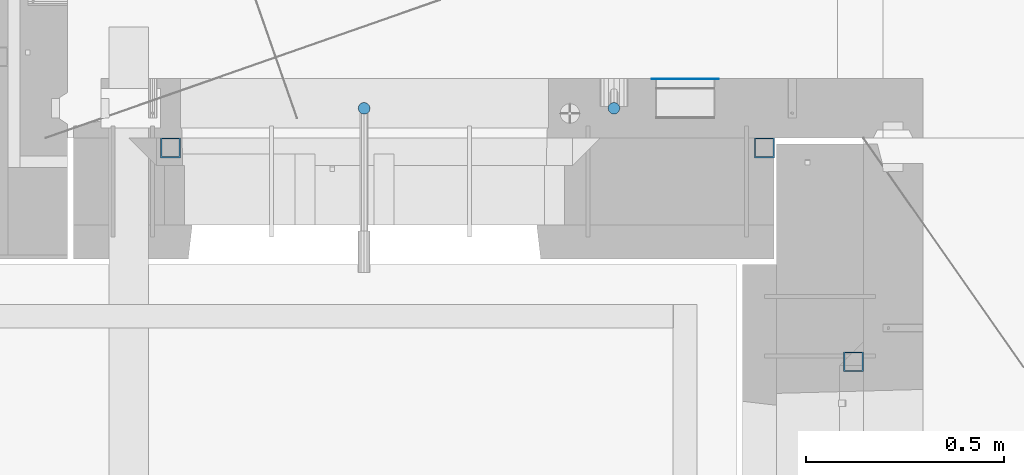
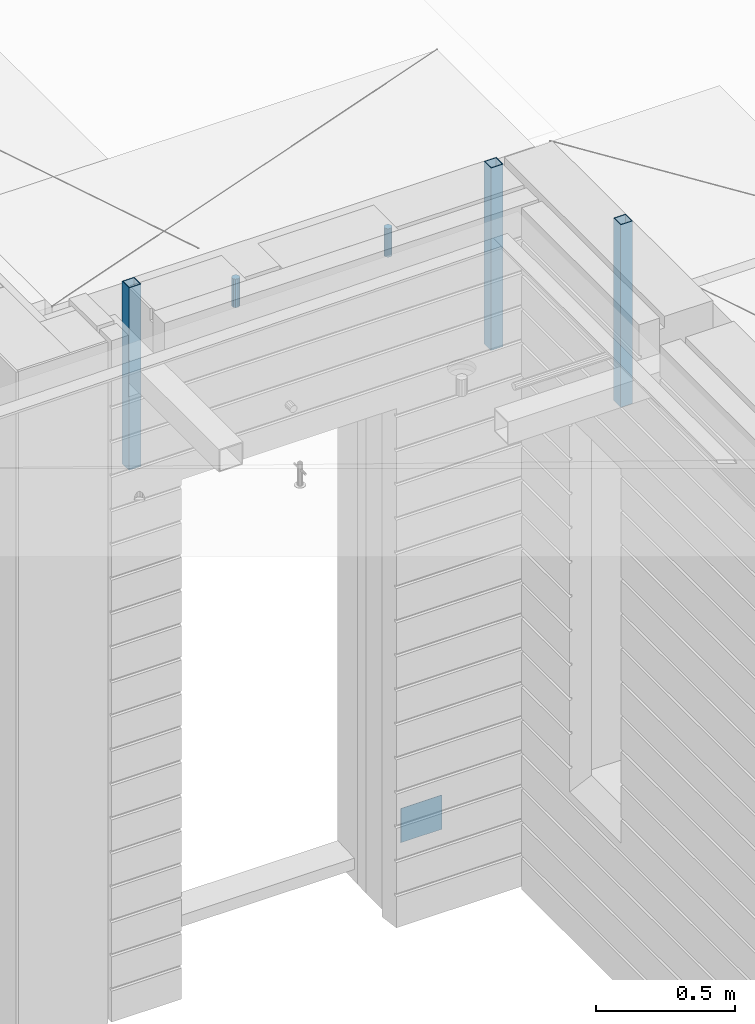
# One storey, part 12 of 349: 6 columns, 6 elements without a shape of their own.
"""IFC2X3 building model written with IfcOpenShell, lengths in millimetres."""

from ifc_helpers import new_model, si_unit, frame, origin_with_axes, place, context, subcontext, project, spatial, faceted_brep, material, type_object, element, aggregate, save


model = new_model("IFC2X3")

# Units and contexts
model_context = context("Model", 3, precision=1e-05, world=origin_with_axes())
body_context = subcontext(model_context, "Body", "Model", "MODEL_VIEW")
ifc_project = project(units=[si_unit("LENGTHUNIT", "METRE", prefix="MILLI"), si_unit("AREAUNIT", "SQUARE_METRE"), si_unit("VOLUMEUNIT", "CUBIC_METRE"), si_unit("MASSUNIT", "GRAM", prefix="KILO"), si_unit("TIMEUNIT", "SECOND"), si_unit("PLANEANGLEUNIT", "RADIAN"), si_unit("SOLIDANGLEUNIT", "STERADIAN"), si_unit("THERMODYNAMICTEMPERATUREUNIT", "DEGREE_CELSIUS"), si_unit("LUMINOUSINTENSITYUNIT", "LUMEN")], contexts=[model_context])

# Site, building, storey
site_placement = place(None, origin_with_axes())
site = spatial("IfcSite", under=ifc_project, at=site_placement, CompositionType="ELEMENT")
building_placement = place(site_placement, origin_with_axes())
building = spatial("IfcBuilding", under=site, at=building_placement, CompositionType="ELEMENT")
storey_placement = place(building_placement, origin_with_axes())
storey = spatial("IfcBuildingStorey", under=building, at=storey_placement, Name="4", CompositionType="ELEMENT", Elevation=0.0)

# Assemblies, columns
assembly_1_placement = place(storey_placement, origin_with_axes())
assembly_1 = element("IfcElementAssembly", 1, at=assembly_1_placement, inside=storey, AssemblyPlace="NOTDEFINED", PredefinedType="REINFORCEMENT_UNIT")
ifc_material_1 = material()
column_type_1 = type_object("IfcColumnType", Name="D30", PredefinedType="NOTDEFINED")
column_1_placement = place(assembly_1_placement, frame((9379.99827996565, 11025.0, 93407.5), z_axis=(0.0, -1.0, 0.0), x_axis=(0.0, 0.0, 1.0)))
column_1 = element("IfcColumn", 2, at=column_1_placement, type_object=column_type_1, material=ifc_material_1, ObjectType="D30", context=body_context, shape_type="Brep", body=[
    faceted_brep([(0.0, -15.0, 0.0), (0.0, -12.9903810567666, -7.5), (125.0, -12.9903810567666, -7.5), (125.0, -15.0, 0.0), (0.0, -7.5, -12.9903810567666), (125.0, -7.5, -12.9903810567666), (0.0, 0.0, -15.0), (125.0, 0.0, -15.0), (0.0, 7.5, -12.9903810567666), (125.0, 7.5, -12.9903810567666), (0.0, 12.9903810567666, -7.5), (125.0, 12.9903810567666, -7.5), (0.0, 15.0, 0.0), (125.0, 15.0, 0.0), (0.0, 12.9903810567666, 7.5), (125.0, 12.9903810567666, 7.5), (0.0, 7.5, 12.9903810567666), (125.0, 7.5, 12.9903810567666), (0.0, 0.0, 15.0), (125.0, 0.0, 15.0), (0.0, -7.5, 12.9903810567666), (125.0, -7.5, 12.9903810567666), (0.0, -12.9903810567666, 7.5), (125.0, -12.9903810567666, 7.5)], [[[0, 1, 2, 3]], [[1, 4, 5, 2]], [[4, 6, 7, 5]], [[6, 8, 9, 7]], [[8, 10, 11, 9]], [[10, 12, 13, 11]], [[12, 14, 15, 13]], [[14, 16, 17, 15]], [[16, 18, 19, 17]], [[18, 20, 21, 19]], [[20, 22, 23, 21]], [[22, 0, 3, 23]], [[5, 7, 9, 11, 13, 15, 17, 19, 21, 23, 3, 2]], [[22, 20, 18, 16, 14, 12, 10, 8, 6, 4, 1, 0]]]),
])
column_2_placement = place(assembly_1_placement, frame((8748.99633326467, 11025.0000000071, 93407.5), z_axis=(0.0, 1.0, 0.0), x_axis=(0.0, 0.0, 1.0)))
column_2 = element("IfcColumn", 3, at=column_2_placement, type_object=column_type_1, material=ifc_material_1, ObjectType="D30", context=body_context, shape_type="Brep", body=[
    faceted_brep([(0.0, -15.0, 0.0), (0.0, -12.9903810567666, -7.5), (125.0, -12.9903810567666, -7.5), (125.0, -15.0, 0.0), (0.0, -7.5, -12.9903810567666), (125.0, -7.5, -12.9903810567666), (0.0, 0.0, -15.0), (125.0, 0.0, -15.0), (0.0, 7.5, -12.9903810567666), (125.0, 7.5, -12.9903810567666), (0.0, 12.9903810567666, -7.5), (125.0, 12.9903810567666, -7.5), (0.0, 15.0, 0.0), (125.0, 15.0, 0.0), (0.0, 12.9903810567666, 7.5), (125.0, 12.9903810567666, 7.5), (0.0, 7.5, 12.9903810567666), (125.0, 7.5, 12.9903810567666), (0.0, 0.0, 15.0), (125.0, 0.0, 15.0), (0.0, -7.5, 12.9903810567666), (125.0, -7.5, 12.9903810567666), (0.0, -12.9903810567666, 7.5), (125.0, -12.9903810567666, 7.5)], [[[0, 1, 2, 3]], [[1, 4, 5, 2]], [[4, 6, 7, 5]], [[6, 8, 9, 7]], [[8, 10, 11, 9]], [[10, 12, 13, 11]], [[12, 14, 15, 13]], [[14, 16, 17, 15]], [[16, 18, 19, 17]], [[18, 20, 21, 19]], [[20, 22, 23, 21]], [[22, 0, 3, 23]], [[5, 7, 9, 11, 13, 15, 17, 19, 21, 23, 3, 2]], [[22, 20, 18, 16, 14, 12, 10, 8, 6, 4, 1, 0]]]),
])
assembly_2_placement = place(assembly_1_placement, origin_with_axes())
assembly_2 = element("IfcElementAssembly", 4, at=assembly_2_placement, Name="Steel Assembly", AssemblyPlace="NOTDEFINED", PredefinedType="NOTDEFINED")
ifc_material_2 = material(Name="Undefined")
column_type_2 = type_object("IfcColumnType", PredefinedType="NOTDEFINED")
column_3_placement = place(assembly_2_placement, frame((9560.0000000031, 11098.9999999984, 90754.9999999985), z_axis=(0.0, 1.0, 0.0), x_axis=(0.0, 0.0, 1.0)))
column_3 = element("IfcColumn", 5, at=column_3_placement, type_object=column_type_2, material=ifc_material_2, Name="SPK2", context=body_context, shape_type="Brep", body=[
    faceted_brep([(0.0, 85.0, -1.0), (0.0, 85.0, 1.0), (150.0, 85.0, 1.0), (150.0, 85.0, -1.0), (0.0, -85.0, 1.0), (150.0, -85.0, 1.0), (0.0, -85.0, -1.0), (150.0, -85.0, -1.0)], [[[0, 1, 2, 3]], [[1, 4, 5, 2]], [[4, 6, 7, 5]], [[6, 0, 3, 7]], [[5, 7, 3, 2]], [[6, 4, 1, 0]]]),
])
aggregate(assembly_2, [column_3])
assembly_3_placement = place(assembly_1_placement, origin_with_axes())
assembly_3 = element("IfcElementAssembly", 6, at=assembly_3_placement, Name="Steel Assembly", AssemblyPlace="NOTDEFINED", PredefinedType="RIGID_FRAME")
ifc_material_3 = material(Name="STEEL/S355J2")
column_type_3 = type_object("IfcColumnType", Name="50X50X3", PredefinedType="NOTDEFINED")
column_4_placement = place(assembly_3_placement, frame((8260.0, 10925.0, 92940.0), z_axis=(1.0, 0.0, 0.0), x_axis=(0.0, 0.0, 1.0)))
column_4 = element("IfcColumn", 7, at=column_4_placement, type_object=column_type_3, material=ifc_material_3, ObjectType="50X50X3", context=body_context, shape_type="Brep", body=[
    faceted_brep([(0.0, 22.0, -22.0), (0.0, -22.0, -22.0), (800.0, -22.0, -22.0), (800.0, 22.0, -22.0), (0.0, -22.0, 22.0), (800.0, -22.0, 22.0), (0.0, 22.0, 22.0), (800.0, 22.0, 22.0), (0.0, 25.0, -25.0), (0.0, 25.0, 25.0), (800.0, 25.0, 25.0), (800.0, 25.0, -25.0), (0.0, -25.0, 25.0), (800.0, -25.0, 25.0), (0.0, -25.0, -25.0), (800.0, -25.0, -25.0)], [[[0, 1, 2, 3]], [[1, 4, 5, 2]], [[4, 6, 7, 5]], [[6, 0, 3, 7]], [[8, 9, 10, 11]], [[9, 12, 13, 10]], [[12, 14, 15, 13]], [[14, 8, 11, 15]], [[13, 15, 11, 10], [5, 7, 3, 2]], [[14, 12, 9, 8], [6, 4, 1, 0]]]),
])
aggregate(assembly_3, [column_4])
assembly_4_placement = place(assembly_1_placement, origin_with_axes())
assembly_4 = element("IfcElementAssembly", 8, at=assembly_4_placement, Name="Steel Assembly", AssemblyPlace="NOTDEFINED", PredefinedType="RIGID_FRAME")
aggregate(assembly_1, [column_1, column_2, assembly_2, assembly_3, assembly_4])
column_5_placement = place(assembly_4_placement, frame((9760.0, 10925.0, 92940.0), z_axis=(1.0, 0.0, 0.0), x_axis=(0.0, 0.0, 1.0)))
column_5 = element("IfcColumn", 9, at=column_5_placement, type_object=column_type_3, material=ifc_material_3, ObjectType="50X50X3", context=body_context, shape_type="Brep", body=[
    faceted_brep([(0.0, 22.0, -22.0), (0.0, -22.0, -22.0), (800.0, -22.0, -22.0), (800.0, 22.0, -22.0), (0.0, -22.0, 22.0), (800.0, -22.0, 22.0), (0.0, 22.0, 22.0), (800.0, 22.0, 22.0), (0.0, 25.0, -25.0), (0.0, 25.0, 25.0), (800.0, 25.0, 25.0), (800.0, 25.0, -25.0), (0.0, -25.0, 25.0), (800.0, -25.0, 25.0), (0.0, -25.0, -25.0), (800.0, -25.0, -25.0)], [[[0, 1, 2, 3]], [[1, 4, 5, 2]], [[4, 6, 7, 5]], [[6, 0, 3, 7]], [[8, 9, 10, 11]], [[9, 12, 13, 10]], [[12, 14, 15, 13]], [[14, 8, 11, 15]], [[13, 15, 11, 10], [5, 7, 3, 2]], [[14, 12, 9, 8], [6, 4, 1, 0]]]),
])
aggregate(assembly_4, [column_5])

# Assemblies, column
assembly_5_placement = place(storey_placement, origin_with_axes())
assembly_5 = element("IfcElementAssembly", 10, at=assembly_5_placement, inside=storey, AssemblyPlace="NOTDEFINED", PredefinedType="REINFORCEMENT_UNIT")
assembly_6_placement = place(assembly_5_placement, origin_with_axes())
assembly_6 = element("IfcElementAssembly", 11, at=assembly_6_placement, Name="Steel Assembly", AssemblyPlace="NOTDEFINED", PredefinedType="RIGID_FRAME")
aggregate(assembly_5, [assembly_6])
column_6_placement = place(assembly_6_placement, frame((9985.0, 10385.0, 92940.0), z_axis=(0.0, 1.0, 0.0), x_axis=(0.0, 0.0, 1.0)))
column_6 = element("IfcColumn", 12, at=column_6_placement, type_object=column_type_3, material=ifc_material_3, ObjectType="50X50X3", context=body_context, shape_type="Brep", body=[
    faceted_brep([(0.0, 22.0, -22.0), (0.0, -22.0, -22.0), (800.0, -22.0, -22.0), (800.0, 22.0, -22.0), (0.0, -22.0, 22.0), (800.0, -22.0, 22.0), (0.0, 22.0, 22.0), (800.0, 22.0, 22.0), (0.0, 25.0, -25.0), (0.0, 25.0, 25.0), (800.0, 25.0, 25.0), (800.0, 25.0, -25.0), (0.0, -25.0, 25.0), (800.0, -25.0, 25.0), (0.0, -25.0, -25.0), (800.0, -25.0, -25.0)], [[[0, 1, 2, 3]], [[1, 4, 5, 2]], [[4, 6, 7, 5]], [[6, 0, 3, 7]], [[8, 9, 10, 11]], [[9, 12, 13, 10]], [[12, 14, 15, 13]], [[14, 8, 11, 15]], [[13, 15, 11, 10], [5, 7, 3, 2]], [[14, 12, 9, 8], [6, 4, 1, 0]]]),
])
aggregate(assembly_6, [column_6])

save(model, "model.ifc")
